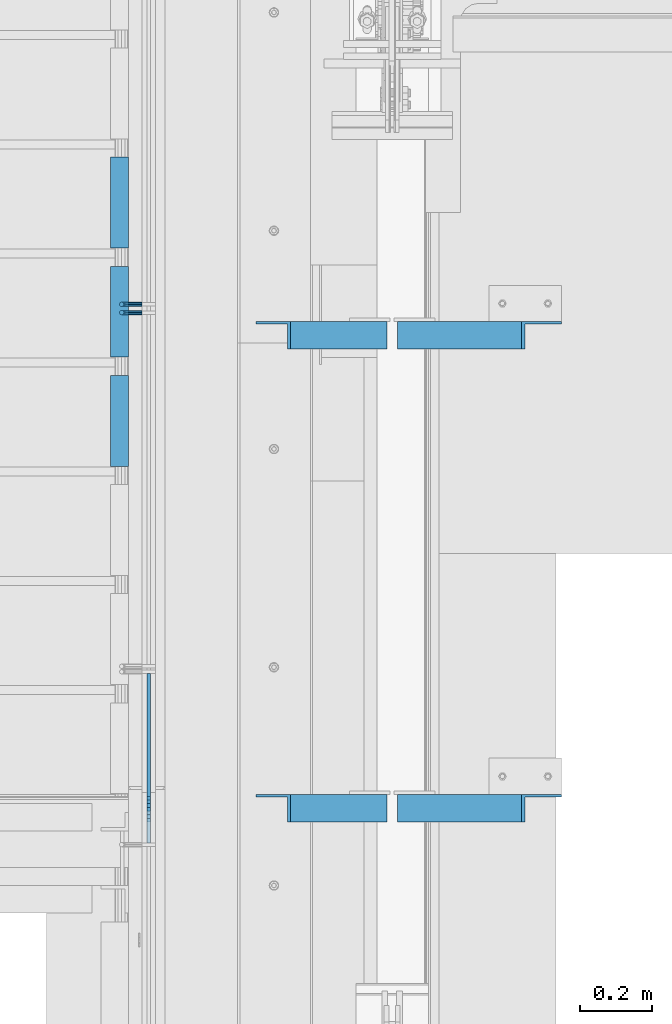
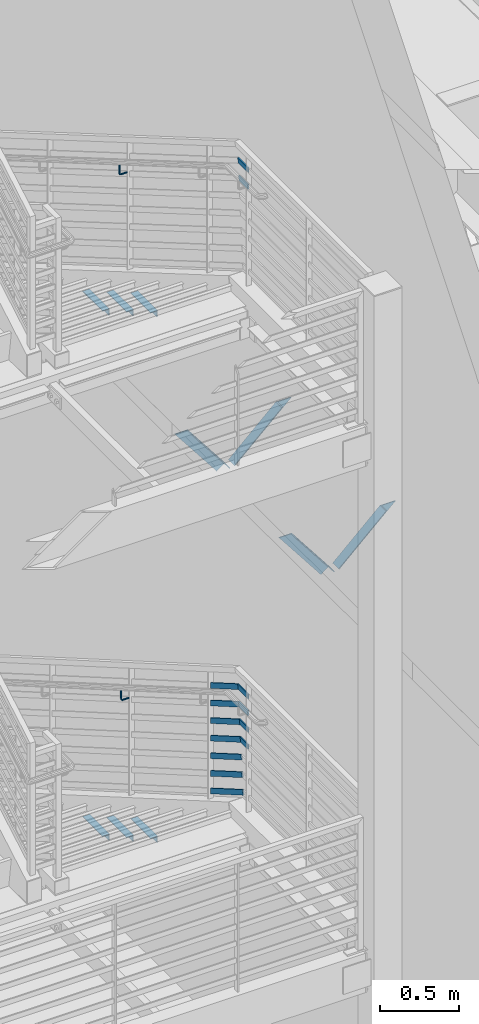
# One storey, part 868 of 1179: 14 beams, 11 members, 8 elements without a shape of their own.
"""IFC2X3 building model written with IfcOpenShell, lengths in millimetres."""

import ifcopenshell
import ifcopenshell.guid

model = None  # the IFC model being written
_history = None  # IfcOwnerHistory: only IFC2X3 demands one
_inside = {}  # id of a spatial element -> (the spatial element, [elements in it])
_under = {}  # id of a project, library or spatial element -> (it, [spatial elements below it])
_declared = {}  # id of a project -> (the project, [libraries it declares])
_typed = {}  # id of a type object -> (the type object, [elements of that type])
_made_of = {}  # id of a material, layer set ... -> (it, [elements and type objects made of it])


def new_model(schema):
    """Start an empty IFC model of exactly this schema.

    Asked for "IFC4X3", IfcOpenShell would pick the latest addendum, in which some entities
    have other attributes; the version numbers below select the first issue.
    IFC2X3 requires an IfcOwnerHistory on every rooted entity: one is made here for all.
    """
    global model, _history
    if schema == "IFC4X3":
        model = ifcopenshell.file(schema_version=(4, 3, 0, 0))
    else:
        model = ifcopenshell.file(schema=schema)
    _inside.clear()
    _under.clear()
    _declared.clear()
    _typed.clear()
    _made_of.clear()
    _history = None
    if model.schema == "IFC2X3":
        org = make("IfcOrganization", Name="unknown")
        user = make(
            "IfcPersonAndOrganization",
            ThePerson=make("IfcPerson", FamilyName="unknown"),
            TheOrganization=org,
        )
        app = make(
            "IfcApplication",
            ApplicationDeveloper=org,
            Version="unknown",
            ApplicationFullName="unknown",
            ApplicationIdentifier="unknown",
        )
        _history = make(
            "IfcOwnerHistory",
            OwningUser=user,
            OwningApplication=app,
            ChangeAction="ADDED",
            CreationDate=0,
        )
    return model


def make(cls, **values):
    """One entity of the class cls with the attributes given. An attribute that is None is left unset."""
    return model.create_entity(
        cls, **{name: value for name, value in values.items() if value is not None}
    )


def rooted(cls, **values):
    """An entity with a GlobalId (a new one), such as an element, a storey or a relation."""
    return make(cls, GlobalId=ifcopenshell.guid.new(), OwnerHistory=_history, **values)


def si_unit(unit_type, name, prefix=None):
    """IfcSIUnit, for example si_unit("LENGTHUNIT", "METRE", prefix="MILLI")."""
    return make("IfcSIUnit", UnitType=unit_type, Prefix=prefix, Name=name)


def assignment(units):
    """IfcUnitAssignment: the units of a project."""
    return None if units is None else make("IfcUnitAssignment", Units=units)


def point(xyz):
    """IfcCartesianPoint."""
    return None if xyz is None else make("IfcCartesianPoint", Coordinates=xyz)


def direction(xyz):
    """IfcDirection."""
    return None if xyz is None else make("IfcDirection", DirectionRatios=xyz)


def frame(location, z_axis=None, x_axis=None):
    """IfcAxis2Placement3D, a coordinate frame: its origin and axes. An axis left out is left unset."""
    return make(
        "IfcAxis2Placement3D",
        Location=point(location),
        Axis=direction(z_axis),
        RefDirection=direction(x_axis),
    )


def origin_with_axes():
    """The frame at (0, 0, 0) with the z axis (0, 0, 1) and the x axis (1, 0, 0) written out."""
    return frame((0.0, 0.0, 0.0), z_axis=(0.0, 0.0, 1.0), x_axis=(1.0, 0.0, 0.0))


def place(relative_to, where):
    """IfcLocalPlacement: puts the frame where relative to a parent placement (None: the world)."""
    return make(
        "IfcLocalPlacement", PlacementRelTo=relative_to, RelativePlacement=where
    )


def context(
    kind, dimensions, precision=None, world=None, true_north=None, identifier=None
):
    """IfcGeometricRepresentationContext, for example the 3D "Model" context."""
    return make(
        "IfcGeometricRepresentationContext",
        ContextIdentifier=identifier,
        ContextType=kind,
        CoordinateSpaceDimension=dimensions,
        Precision=precision,
        WorldCoordinateSystem=world,
        TrueNorth=true_north,
    )


def subcontext(parent, identifier, kind, view, scale=None):
    """IfcGeometricRepresentationSubContext, for example "Body" below "Model"."""
    return make(
        "IfcGeometricRepresentationSubContext",
        ContextIdentifier=identifier,
        ContextType=kind,
        ParentContext=parent,
        TargetScale=scale,
        TargetView=view,
    )


def project(units=None, contexts=None):
    """IfcProject with its units and contexts."""
    return rooted(
        "IfcProject",
        Name="project",
        RepresentationContexts=contexts,
        UnitsInContext=assignment(units),
    )


def spatial(cls, under=None, at=None, **own):
    """A site, building, storey or space (cls), placed at a placement, below another one or the project."""
    s = rooted(cls, ObjectPlacement=at, **own)
    if under is not None:
        _under.setdefault(under.id(), (under, []))[1].append(s)
    return s


def faces_of(points, faces, orient=None, outer=None):
    """IfcFace entities. A face is a list of loops; a loop is a list of indices into points, from 0.

    orient and outer hold one flag for each loop. By default every Orientation is true, the
    first loop of a face is its IfcFaceOuterBound and the others are IfcFaceBound.
    """
    made = []
    for i, loops in enumerate(faces):
        bounds = []
        for j, loop in enumerate(loops):
            is_outer = j == 0 if outer is None else outer[i][j]
            bounds.append(
                make(
                    "IfcFaceOuterBound" if is_outer else "IfcFaceBound",
                    Bound=make("IfcPolyLoop", Polygon=[points[k] for k in loop]),
                    Orientation=True if orient is None else orient[i][j],
                )
            )
        made.append(make("IfcFace", Bounds=bounds))
    return made


def faceted_brep(points, faces, orient=None, outer=None, voids=None):
    """IfcFacetedBrep: a solid bounded by flat faces; with voids (closed shells), ...WithVoids."""
    shared = [point(p) for p in points]
    hull = make("IfcClosedShell", CfsFaces=faces_of(shared, faces, orient, outer))
    if voids is None:
        return make("IfcFacetedBrep", Outer=hull)
    return make(
        "IfcFacetedBrepWithVoids",
        Outer=hull,
        Voids=[
            make(cls, CfsFaces=faces_of(shared, fs, o, b)) for cls, fs, o, b in voids
        ],
    )


def shape(context_of_items, identifier, shape_type, items):
    """IfcShapeRepresentation: the items that make up one representation, for example the "Body"."""
    return make(
        "IfcShapeRepresentation",
        ContextOfItems=context_of_items,
        RepresentationIdentifier=identifier,
        RepresentationType=shape_type,
        Items=items,
    )


def material(Name=None, Category=None):
    """IfcMaterial."""
    return make("IfcMaterial", Name=Name, Category=Category)


def made_of(thing, what):
    """Note that an element or type object is made of a material, layer set ...; save() writes the relation."""
    if what is not None:
        _made_of.setdefault(what.id(), (what, []))[1].append(thing)
    return thing


def type_object(cls, material=None, **own):
    """A type object (cls), such as IfcWallType, which elements share."""
    return made_of(rooted(cls, **own), material)


def element(
    cls,
    number,
    at=None,
    inside=None,
    cuts=None,
    type_object=None,
    material=None,
    context=None,
    identifier="Body",
    shape_type=None,
    held_by="IfcProductDefinitionShape",
    body=None,
    shapes=None,
    **own,
):
    """One element of the class cls, such as IfcWall. Its Tag is "e" and its number.

    at: its placement. inside: the storey or other place that contains it. cuts: it is an
    opening in that element (IfcRelVoidsElement). A single representation is given by context,
    identifier, shape_type and body (its items); several are given by shapes. held_by: the class
    of the entity that holds the representations. save() writes the other relations.
    """
    e = rooted(cls, Tag="e%d" % number, ObjectPlacement=at, **own)
    if body is not None:
        shapes = [shape(context, identifier, shape_type, body)]
    if shapes is not None:
        e.Representation = make(held_by, Representations=shapes)
    if inside is not None:
        _inside.setdefault(inside.id(), (inside, []))[1].append(e)
    if cuts is not None:
        rooted(
            "IfcRelVoidsElement", RelatingBuildingElement=cuts, RelatedOpeningElement=e
        )
    if type_object is not None:
        _typed.setdefault(type_object.id(), (type_object, []))[1].append(e)
    return made_of(e, material)


def aggregate(whole, parts):
    """IfcRelAggregates: a whole, such as a stair, and the parts it consists of."""
    return rooted("IfcRelAggregates", RelatingObject=whole, RelatedObjects=parts)


def save(model, path):
    """Write the relations noted so far, then the file.

    IfcRelAggregates (storeys below a building ...), IfcRelContainedInSpatialStructure (elements
    in a storey), IfcRelDefinesByType, IfcRelAssociatesMaterial and IfcRelDeclares: one each for
    every whole, place, type object, material and project.
    """
    for whole, parts in _under.values():
        aggregate(whole, parts)
    for where, things in _inside.values():
        rooted(
            "IfcRelContainedInSpatialStructure",
            RelatedElements=things,
            RelatingStructure=where,
        )
    for kind, things in _typed.values():
        rooted("IfcRelDefinesByType", RelatedObjects=things, RelatingType=kind)
    for what, things in _made_of.values():
        rooted("IfcRelAssociatesMaterial", RelatedObjects=things, RelatingMaterial=what)
    for by, libraries in _declared.values():
        rooted("IfcRelDeclares", RelatingContext=by, RelatedDefinitions=libraries)
    model.write(path)


model = new_model("IFC2X3")

# Units and contexts
model_context = context("Model", 3, precision=1e-05, world=origin_with_axes())
body_context = subcontext(model_context, "Body", "Model", "MODEL_VIEW")
ifc_project = project(units=[si_unit("LENGTHUNIT", "METRE", prefix="MILLI"), si_unit("AREAUNIT", "SQUARE_METRE"), si_unit("VOLUMEUNIT", "CUBIC_METRE"), si_unit("MASSUNIT", "GRAM", prefix="KILO"), si_unit("TIMEUNIT", "SECOND"), si_unit("PLANEANGLEUNIT", "RADIAN"), si_unit("SOLIDANGLEUNIT", "STERADIAN"), si_unit("THERMODYNAMICTEMPERATUREUNIT", "DEGREE_CELSIUS"), si_unit("LUMINOUSINTENSITYUNIT", "LUMEN")], contexts=[model_context])

# Site, building, storey
site_placement = place(None, origin_with_axes())
site = spatial("IfcSite", under=ifc_project, at=site_placement, CompositionType="ELEMENT")
building_placement = place(site_placement, origin_with_axes())
building = spatial("IfcBuilding", under=site, at=building_placement, Name="Undefined", CompositionType="ELEMENT")
storey_placement = place(building_placement, origin_with_axes())
storey = spatial("IfcBuildingStorey", under=building, at=storey_placement, Name="Undefined", CompositionType="ELEMENT", Elevation=0.0)

# Assembly, beams
assembly_1_placement = place(storey_placement, origin_with_axes())
assembly_1 = element("IfcElementAssembly", 1, at=assembly_1_placement, inside=storey, Name="STRINGER", AssemblyPlace="NOTDEFINED", PredefinedType="RIGID_FRAME")
ifc_material = material(Name="STEEL/A36")
beam_type_1 = type_object("IfcBeamType", Name="L2X2X3/16", PredefinedType="NOTDEFINED")
beam_1_placement = place(assembly_1_placement, frame((-330.199999984874, 33060.3356226176, 5400.67499956045), z_axis=(-1.0, 0.0, 0.0), x_axis=(0.0, -1.0, 0.0)))
beam_1 = element("IfcBeam", 2, at=beam_1_placement, type_object=beam_type_1, material=ifc_material, Name="ANGLE", ObjectType="L2X2X3/16", context=body_context, shape_type="Brep", body=[
    faceted_brep([(0.0, 25.3999999999996, -25.4000000000015), (0.0, 25.3999999999996, 25.4000000000015), (254.0, 25.3999999999996, 25.4000000000001), (254.0, 25.3999999999996, -25.4000000000001), (0.0, 20.6374999999998, 25.4000000000015), (254.0, 20.6374999999998, 25.4000000000001), (0.0, 20.6374999999998, -20.6374999999971), (254.0, 20.6374999999998, -20.6374999999998), (0.0, -25.3999999999996, -20.6374999999971), (254.0, -25.3999999999996, -20.6374999999998), (0.0, -25.3999999999996, -25.4000000000015), (254.0, -25.3999999999996, -25.4000000000001)], [[[0, 1, 2, 3]], [[1, 4, 5, 2]], [[4, 6, 7, 5]], [[6, 8, 9, 7]], [[8, 10, 11, 9]], [[10, 0, 3, 11]], [[5, 7, 9, 11, 3, 2]], [[10, 8, 6, 4, 1, 0]]]),
])
beam_2_placement = place(assembly_1_placement, frame((-330.19999998693, 33365.1356225536, 5222.87499945075), z_axis=(-1.0, 0.0, 0.0), x_axis=(0.0, -1.0, 0.0)))
beam_2 = element("IfcBeam", 3, at=beam_2_placement, type_object=beam_type_1, material=ifc_material, Name="ANGLE", ObjectType="L2X2X3/16", context=body_context, shape_type="Brep", body=[
    faceted_brep([(0.0, 25.3999999999996, -25.4000000000015), (0.0, 25.3999999999996, 25.4000000000015), (254.0, 25.3999999999996, 25.4000000000001), (254.0, 25.3999999999996, -25.4000000000001), (0.0, 20.6374999999998, 25.4000000000015), (254.0, 20.6374999999998, 25.4000000000001), (0.0, 20.6374999999998, -20.6374999999971), (254.0, 20.6374999999998, -20.6374999999998), (0.0, -25.3999999999996, -20.6374999999971), (254.0, -25.3999999999996, -20.6374999999998), (0.0, -25.3999999999996, -25.4000000000015), (254.0, -25.3999999999996, -25.4000000000001)], [[[0, 1, 2, 3]], [[1, 4, 5, 2]], [[4, 6, 7, 5]], [[6, 8, 9, 7]], [[8, 10, 11, 9]], [[10, 0, 3, 11]], [[5, 7, 9, 11, 3, 2]], [[10, 8, 6, 4, 1, 0]]]),
])
beam_3_placement = place(assembly_1_placement, frame((-330.199999988985, 33669.9356224896, 5045.07499934105), z_axis=(-1.0, 0.0, 0.0), x_axis=(0.0, -1.0, 0.0)))
beam_3 = element("IfcBeam", 4, at=beam_3_placement, type_object=beam_type_1, material=ifc_material, Name="ANGLE", ObjectType="L2X2X3/16", context=body_context, shape_type="Brep", body=[
    faceted_brep([(0.0, 25.3999999999996, -25.4000000000015), (0.0, 25.3999999999996, 25.4000000000015), (254.0, 25.3999999999996, 25.4000000000001), (254.0, 25.3999999999996, -25.4000000000001), (0.0, 20.6374999999998, 25.4000000000015), (254.0, 20.6374999999998, 25.4000000000001), (0.0, 20.6374999999998, -20.6374999999971), (254.0, 20.6374999999998, -20.6374999999998), (0.0, -25.3999999999996, -20.6374999999971), (254.0, -25.3999999999996, -20.6374999999998), (0.0, -25.3999999999996, -25.4000000000015), (254.0, -25.3999999999996, -25.4000000000001)], [[[0, 1, 2, 3]], [[1, 4, 5, 2]], [[4, 6, 7, 5]], [[6, 8, 9, 7]], [[8, 10, 11, 9]], [[10, 0, 3, 11]], [[5, 7, 9, 11, 3, 2]], [[10, 8, 6, 4, 1, 0]]]),
])
aggregate(assembly_1, [beam_1, beam_2, beam_3])

assembly_2_placement = place(storey_placement, origin_with_axes())
assembly_2 = element("IfcElementAssembly", 5, at=assembly_2_placement, inside=storey, Name="STRINGER", AssemblyPlace="NOTDEFINED", PredefinedType="RIGID_FRAME")
beam_4_placement = place(assembly_2_placement, frame((-330.200000005452, 33060.2814779887, 1332.47534229106), z_axis=(-1.0, 0.0, 0.0), x_axis=(0.0, -1.0, 0.0)))
beam_4 = element("IfcBeam", 6, at=beam_4_placement, type_object=beam_type_1, material=ifc_material, Name="ANGLE", ObjectType="L2X2X3/16", context=body_context, shape_type="Brep", body=[
    faceted_brep([(0.0, 25.3999999999996, -25.4000000000015), (0.0, 25.3999999999996, 25.4000000000015), (254.0, 25.3999999999996, 25.4000000000001), (254.0, 25.3999999999996, -25.4000000000001), (0.0, 20.6374999999998, 25.4000000000015), (254.0, 20.6374999999998, 25.4000000000001), (0.0, 20.6374999999998, -20.6374999999971), (254.0, 20.6374999999998, -20.6374999999998), (0.0, -25.3999999999996, -20.6374999999971), (254.0, -25.3999999999996, -20.6374999999998), (0.0, -25.3999999999996, -25.4000000000015), (254.0, -25.3999999999996, -25.4000000000001)], [[[0, 1, 2, 3]], [[1, 4, 5, 2]], [[4, 6, 7, 5]], [[6, 8, 9, 7]], [[8, 10, 11, 9]], [[10, 0, 3, 11]], [[5, 7, 9, 11, 3, 2]], [[10, 8, 6, 4, 1, 0]]]),
])
beam_5_placement = place(assembly_2_placement, frame((-330.200000005412, 33365.0816317228, 1155.99344815391), z_axis=(-1.0, 0.0, 0.0), x_axis=(0.0, -1.0, 0.0)))
beam_5 = element("IfcBeam", 7, at=beam_5_placement, type_object=beam_type_1, material=ifc_material, Name="ANGLE", ObjectType="L2X2X3/16", context=body_context, shape_type="Brep", body=[
    faceted_brep([(0.0, 25.3999999999996, -25.4000000000015), (0.0, 25.3999999999996, 25.4000000000015), (254.0, 25.3999999999996, 25.4000000000001), (254.0, 25.3999999999996, -25.4000000000001), (0.0, 20.6374999999998, 25.4000000000015), (254.0, 20.6374999999998, 25.4000000000001), (0.0, 20.6374999999998, -20.6374999999971), (254.0, 20.6374999999998, -20.6374999999998), (0.0, -25.3999999999996, -20.6374999999971), (254.0, -25.3999999999996, -20.6374999999998), (0.0, -25.3999999999996, -25.4000000000015), (254.0, -25.3999999999996, -25.4000000000001)], [[[0, 1, 2, 3]], [[1, 4, 5, 2]], [[4, 6, 7, 5]], [[6, 8, 9, 7]], [[8, 10, 11, 9]], [[10, 0, 3, 11]], [[5, 7, 9, 11, 3, 2]], [[10, 8, 6, 4, 1, 0]]]),
])
beam_6_placement = place(assembly_2_placement, frame((-330.200000005372, 33669.8817854569, 979.51155401677), z_axis=(-1.0, 0.0, 0.0), x_axis=(0.0, -1.0, 0.0)))
beam_6 = element("IfcBeam", 8, at=beam_6_placement, type_object=beam_type_1, material=ifc_material, Name="ANGLE", ObjectType="L2X2X3/16", context=body_context, shape_type="Brep", body=[
    faceted_brep([(0.0, 25.3999999999996, -25.4000000000015), (0.0, 25.3999999999996, 25.4000000000015), (254.0, 25.3999999999996, 25.4000000000001), (254.0, 25.3999999999996, -25.4000000000001), (0.0, 20.6374999999998, 25.4000000000015), (254.0, 20.6374999999998, 25.4000000000001), (0.0, 20.6374999999998, -20.6374999999971), (254.0, 20.6374999999998, -20.6374999999998), (0.0, -25.3999999999996, -20.6374999999971), (254.0, -25.3999999999996, -20.6374999999998), (0.0, -25.3999999999996, -25.4000000000015), (254.0, -25.3999999999996, -25.4000000000001)], [[[0, 1, 2, 3]], [[1, 4, 5, 2]], [[4, 6, 7, 5]], [[6, 8, 9, 7]], [[8, 10, 11, 9]], [[10, 0, 3, 11]], [[5, 7, 9, 11, 3, 2]], [[10, 8, 6, 4, 1, 0]]]),
])
aggregate(assembly_2, [beam_4, beam_5, beam_6])

# Assembly, beam
assembly_3_placement = place(storey_placement, origin_with_axes())
assembly_3 = element("IfcElementAssembly", 9, at=assembly_3_placement, inside=storey, Name="GUARDRAIL", AssemblyPlace="NOTDEFINED", PredefinedType="RIGID_FRAME")
beam_type_2 = type_object("IfcBeamType", PredefinedType="NOTDEFINED")
beam_7_placement = place(assembly_3_placement, frame((-266.699999255495, 33258.759324803, 6208.77780560445), z_axis=(0.0, 0.0, 1.0), x_axis=(-1.0, 0.0, 0.0)))
beam_7 = element("IfcBeam", 10, at=beam_7_placement, type_object=beam_type_2, material=ifc_material, Name="BRACKET", context=body_context, shape_type="Brep", body=[
    faceted_brep([(0.0, -4.49012806053361, 4.49012806053452), (0.0, 0.0, 6.34999999999991), (0.0, 4.49012806053361, 4.49012806053452), (0.0, 6.34999999999854, 0.0), (0.0, 4.49012806053361, -4.49012806053452), (0.0, 0.0, -6.34999999999991), (0.0, -4.49012806053361, -4.49012806053452), (0.0, -6.34999999999854, 0.0), (44.4500031699827, 0.0, -6.34999999999991), (44.4500031699827, -4.49012806053361, -4.49012806053452), (44.4500031699827, -6.34999999999854, 2.19733919948339e-09), (44.4500031699827, -4.49012806053361, 4.49012806053452), (44.4500031699827, 0.0, 6.34999999999991), (44.4500031699827, 4.49012806053361, 4.49012806053452), (44.4500031699827, 6.34999999999854, 0.0), (44.4500031699827, 4.49012806053361, -4.49012806053452), (53.0450671075391, 4.4901280570557, -2.18708762112465), (53.97500307462, -4.32919478043914e-09, -3.79778396764459), (53.0450671022344, -4.49012806401151, -2.1870876194389), (50.8000030708674, -6.35000000142099, 1.70147734757802), (48.5549390416977, -4.4901280599006, 5.59004231389645), (47.6250030746168, 1.48793333210051e-09, 7.20073866041594), (48.5549390470023, 4.49012806117025, 5.5900423122107), (50.8000030783693, 6.34999999857973, 1.70147734519378), (55.4485256393576, 6.34999999469437, 6.34999990618098), (59.337090604122, 4.49012805180246, 4.10493587545716), (51.5599606707875, 4.49012805866005, 8.59506393599531), (49.9492643188311, -4.54747350886464e-10, 9.52499990463002), (51.5599606615996, -4.4901280624108, 8.59506393379797), (55.4485256263639, -6.35000000530636, 6.34999990307369), (59.337090594938, -4.49012806926839, 4.10493587326664), (60.9477869468905, -1.0153598850593e-08, 3.17499990462466), (61.6401310450869, 4.49012804462109, 12.6999998130159), (63.5000029792477, -1.81098585017025e-08, 12.6999998092651), (57.1500029867496, 6.3499999893902, 12.6999998145698), (52.6598749240178, 4.49012805522943, 12.6999998130159), (50.8000029792477, -3.10683390125632e-09, 12.6999998092651), (52.6598749134085, -4.49012806583778, 12.6999998055144), (57.1500029739432, -6.35000001061053, 12.6999998039605), (61.6401310344776, -4.49012807644976, 12.6999998055144), (63.5000029792478, -6.94672053214163e-08, 76.1999999999989), (61.6401294880352, -4.49012904147821, 73.5807586715764), (57.1500014109847, -6.35000090467656, 72.4958334126568), (52.6598733669657, -4.49012891602615, 73.5807587357776), (50.8000029792478, -5.78438630327582e-08, 76.1999999999989), (52.6598734909962, 4.49012713825505, 78.8192414384375), (57.1500015765077, 6.34999900287221, 79.9041666981866), (61.6401296120657, 4.49012701564061, 78.8192413758952)], [[[0, 1, 2, 3, 4, 5, 6, 7]], [[6, 5, 8, 9]], [[7, 6, 9, 10]], [[0, 7, 10, 11]], [[1, 0, 11, 12]], [[2, 1, 12, 13]], [[3, 2, 13, 14]], [[4, 3, 14, 15]], [[5, 4, 15, 8]], [[8, 15, 16, 17]], [[9, 8, 17, 18]], [[10, 9, 18, 19]], [[11, 10, 19, 20]], [[12, 11, 20, 21]], [[13, 12, 21, 22]], [[14, 13, 22, 23]], [[15, 14, 23, 16]], [[23, 24, 25, 16]], [[22, 26, 24, 23]], [[21, 27, 26, 22]], [[20, 28, 27, 21]], [[19, 29, 28, 20]], [[18, 30, 29, 19]], [[17, 31, 30, 18]], [[16, 25, 31, 17]], [[25, 32, 33, 31]], [[24, 34, 32, 25]], [[26, 35, 34, 24]], [[27, 36, 35, 26]], [[28, 37, 36, 27]], [[29, 38, 37, 28]], [[30, 39, 38, 29]], [[31, 33, 39, 30]], [[39, 33, 40, 41]], [[38, 39, 41, 42]], [[37, 38, 42, 43]], [[36, 37, 43, 44]], [[35, 36, 44, 45]], [[34, 35, 45, 46]], [[32, 34, 46, 47]], [[33, 32, 47, 40]], [[46, 45, 44, 43, 42, 41, 40, 47]]]),
])

assembly_4_placement = place(storey_placement, origin_with_axes())
assembly_4 = element("IfcElementAssembly", 11, at=assembly_4_placement, inside=storey, Name="GUARDRAIL", AssemblyPlace="NOTDEFINED", PredefinedType="RIGID_FRAME")
beam_8_placement = place(assembly_4_placement, frame((-266.699999255495, 33235.9000011132, 2154.50375560792), z_axis=(0.0, 0.0, 1.0), x_axis=(-1.0, 0.0, 0.0)))
beam_8 = element("IfcBeam", 12, at=beam_8_placement, type_object=beam_type_2, material=ifc_material, Name="BRACKET", context=body_context, shape_type="Brep", body=[
    faceted_brep([(0.0, -4.49012806053361, 4.49012806053452), (0.0, 0.0, 6.34999999999991), (0.0, 4.49012806053361, 4.49012806053452), (0.0, 6.34999999999854, 0.0), (0.0, 4.49012806053361, -4.49012806053452), (0.0, 0.0, -6.34999999999991), (0.0, -4.49012806053361, -4.49012806053452), (0.0, -6.34999999999854, 0.0), (44.4500031699827, 0.0, -6.34999999999991), (44.4500031699827, -4.49012806053361, -4.49012806053452), (44.4500031699827, -6.34999999999854, 2.19733919948339e-09), (44.4500031699827, -4.49012806053361, 4.49012806053452), (44.4500031699827, 0.0, 6.34999999999991), (44.4500031699827, 4.49012806053361, 4.49012806053452), (44.4500031699827, 6.34999999999854, 0.0), (44.4500031699827, 4.49012806053361, -4.49012806053452), (53.0450671075391, 4.4901280570557, -2.18708762112465), (53.97500307462, -4.32919478043914e-09, -3.79778396764459), (53.0450671022344, -4.49012806401151, -2.1870876194389), (50.8000030708674, -6.35000000142099, 1.70147734757802), (48.5549390416977, -4.4901280599006, 5.59004231389645), (47.6250030746168, 1.48793333210051e-09, 7.20073866041594), (48.5549390470023, 4.49012806117025, 5.5900423122107), (50.8000030783693, 6.34999999857973, 1.70147734519378), (55.4485256393576, 6.34999999469437, 6.34999990618098), (59.337090604122, 4.49012805180246, 4.10493587545716), (51.5599606707875, 4.49012805866005, 8.59506393599531), (49.9492643188311, -4.54747350886464e-10, 9.52499990463002), (51.5599606615996, -4.4901280624108, 8.59506393379797), (55.4485256263639, -6.35000000530636, 6.34999990307369), (59.337090594938, -4.49012806926839, 4.10493587326664), (60.9477869468905, -1.0153598850593e-08, 3.17499990462466), (61.6401310450869, 4.49012804462109, 12.6999998130159), (63.5000029792477, -1.81098585017025e-08, 12.6999998092651), (57.1500029867496, 6.3499999893902, 12.6999998145698), (52.6598749240178, 4.49012805522943, 12.6999998130159), (50.8000029792477, -3.10683390125632e-09, 12.6999998092651), (52.6598749134085, -4.49012806583778, 12.6999998055144), (57.1500029739432, -6.35000001061053, 12.6999998039605), (61.6401310344776, -4.49012807644976, 12.6999998055144), (63.5000029792478, -6.94672053214163e-08, 76.1999999999989), (61.6401296086745, -4.49012715444769, 73.6001774342253), (57.1500015634042, -6.3499991642384, 72.5232956440923), (52.6598734876054, -4.49012727027366, 73.6001773671605), (50.8000029792478, -5.78438630327582e-08, 76.1999999999989), (52.6598733730815, 4.4901289120171, 78.79982245163), (57.150001410549, 6.35000092050541, 79.8767042410086), (61.6401294941506, 4.49012902523828, 78.7998225171859)], [[[0, 1, 2, 3, 4, 5, 6, 7]], [[6, 5, 8, 9]], [[7, 6, 9, 10]], [[0, 7, 10, 11]], [[1, 0, 11, 12]], [[2, 1, 12, 13]], [[3, 2, 13, 14]], [[4, 3, 14, 15]], [[5, 4, 15, 8]], [[8, 15, 16, 17]], [[9, 8, 17, 18]], [[10, 9, 18, 19]], [[11, 10, 19, 20]], [[12, 11, 20, 21]], [[13, 12, 21, 22]], [[14, 13, 22, 23]], [[15, 14, 23, 16]], [[23, 24, 25, 16]], [[22, 26, 24, 23]], [[21, 27, 26, 22]], [[20, 28, 27, 21]], [[19, 29, 28, 20]], [[18, 30, 29, 19]], [[17, 31, 30, 18]], [[16, 25, 31, 17]], [[25, 32, 33, 31]], [[24, 34, 32, 25]], [[26, 35, 34, 24]], [[27, 36, 35, 26]], [[28, 37, 36, 27]], [[29, 38, 37, 28]], [[30, 39, 38, 29]], [[31, 33, 39, 30]], [[39, 33, 40, 41]], [[38, 39, 41, 42]], [[37, 38, 42, 43]], [[36, 37, 43, 44]], [[35, 36, 44, 45]], [[34, 35, 45, 46]], [[32, 34, 46, 47]], [[33, 32, 47, 40]], [[46, 45, 44, 43, 42, 41, 40, 47]]]),
])

# Beam
beam_type_3 = type_object("IfcBeamType", PredefinedType="NOTDEFINED")
beam_9_placement = place(assembly_3_placement, frame((-247.650000711891, 31841.0069917113, 7000.87500003556), z_axis=(0.0, 0.0, 1.0), x_axis=(0.0, -1.0, 0.0)))
beam_9 = element("IfcBeam", 13, at=beam_9_placement, type_object=beam_type_3, material=ifc_material, Name="PLATE", context=body_context, shape_type="Brep", body=[
    faceted_brep([(-22.9619603103856, 4.76249999999999, -19.0500000000002), (-33.2622625921977, 4.76249999999999, 19.0500000000002), (86.2461825391219, 4.76249999999999, 19.0500000000002), (86.2461825391219, 4.76249999999999, -19.0500000000002), (-33.2622625921977, -4.76249999999999, 19.0500000000002), (86.2461825391219, -4.76249999999999, 19.0500000000002), (-22.9619603103856, -4.76249999999999, -19.0500000000002), (86.2461825391219, -4.76249999999999, -19.0500000000002)], [[[0, 1, 2, 3]], [[1, 4, 5, 2]], [[4, 6, 7, 5]], [[6, 0, 3, 7]], [[5, 7, 3, 2]], [[6, 4, 1, 0]]]),
])

beam_10_placement = place(assembly_3_placement, frame((-247.650000724804, 31851.8927060719, 7131.04999999123), z_axis=(0.0, 0.0, 1.0), x_axis=(0.0, -1.0, 0.0)))
beam_10 = element("IfcBeam", 14, at=beam_10_placement, type_object=beam_type_3, material=ifc_material, Name="PLATE", context=body_context, shape_type="Brep", body=[
    faceted_brep([(-22.3765490774094, 4.76249999999999, -19.0500000000002), (-32.6768513592251, 4.76249999999999, 19.0500000000002), (97.1318968997475, 4.76249999999999, 19.0500000000002), (97.1318968997475, 4.76249999999999, -19.0500000000002), (-32.6768513592251, -4.76249999999999, 19.0500000000002), (97.1318968997475, -4.76249999999999, 19.0500000000002), (-22.3765490774094, -4.76249999999999, -19.0500000000002), (97.1318968997475, -4.76249999999999, -19.0500000000002)], [[[0, 1, 2, 3]], [[1, 4, 5, 2]], [[4, 6, 7, 5]], [[6, 0, 3, 7]], [[5, 7, 3, 2]], [[6, 4, 1, 0]]]),
])

aggregate(assembly_3, [beam_7, beam_9, beam_10])

beam_11_placement = place(assembly_4_placement, frame((-247.650000724804, 31848.7630235135, 2667.05291886964), z_axis=(0.0, 0.0, 1.0), x_axis=(0.0, -1.0, 0.0)))
beam_11 = element("IfcBeam", 15, at=beam_11_placement, type_object=beam_type_3, material=ifc_material, Name="PLATE", context=body_context, shape_type="Brep", body=[
    faceted_brep([(5.11704109249331, 4.76249999999999, -19.0500000000002), (-5.1172028383553, 4.76249999999999, 19.0500000000002), (94.0022143409733, 4.76249999999999, 19.0500000000002), (94.0022143409733, 4.76249999999999, -19.0500000000002), (-5.1172028383553, -4.76249999999999, 19.0500000000002), (94.0022143409733, -4.76249999999999, 19.0500000000002), (5.11704109249331, -4.76249999999999, -19.0500000000002), (94.0022143409733, -4.76249999999999, -19.0500000000002)], [[[0, 1, 2, 3]], [[1, 4, 5, 2]], [[4, 6, 7, 5]], [[6, 0, 3, 7]], [[5, 7, 3, 2]], [[6, 4, 1, 0]]]),
])

beam_12_placement = place(assembly_4_placement, frame((-247.650000724804, 31858.9972675265, 2797.22791886683), z_axis=(0.0, 0.0, 1.0), x_axis=(0.0, -1.0, 0.0)))
beam_12 = element("IfcBeam", 16, at=beam_12_placement, type_object=beam_type_3, material=ifc_material, Name="PLATE", context=body_context, shape_type="Brep", body=[
    faceted_brep([(5.11710635485724, 4.76249999999999, -19.0500000000002), (-5.11713757599136, 4.76249999999999, 19.0500000000002), (104.236458353978, 4.76249999999999, 19.0500000000002), (104.236458353978, 4.76249999999999, -19.0500000000002), (-5.11713757599136, -4.76249999999999, 19.0500000000002), (104.236458353978, -4.76249999999999, 19.0500000000002), (5.11710635485724, -4.76249999999999, -19.0500000000002), (104.236458353978, -4.76249999999999, -19.0500000000002)], [[[0, 1, 2, 3]], [[1, 4, 5, 2]], [[4, 6, 7, 5]], [[6, 0, 3, 7]], [[5, 7, 3, 2]], [[6, 4, 1, 0]]]),
])

beam_13_placement = place(assembly_4_placement, frame((-247.650000724804, 31869.2315115286, 2927.40291887029), z_axis=(0.0, 0.0, 1.0), x_axis=(0.0, -1.0, 0.0)))
beam_13 = element("IfcBeam", 17, at=beam_13_placement, type_object=beam_type_3, material=ifc_material, Name="PLATE", context=body_context, shape_type="Brep", body=[
    faceted_brep([(5.11710635485724, 4.76249999999999, -19.0500000000002), (-5.11713757599136, 4.76249999999999, 19.0500000000002), (114.470702356146, 4.76249999999999, 19.0500000000002), (114.470702356146, 4.76249999999999, -19.0500000000002), (-5.11713757599136, -4.76249999999999, 19.0500000000002), (114.470702356146, -4.76249999999999, 19.0500000000002), (5.11710635485724, -4.76249999999999, -19.0500000000002), (114.470702356146, -4.76249999999999, -19.0500000000002)], [[[0, 1, 2, 3]], [[1, 4, 5, 2]], [[4, 6, 7, 5]], [[6, 0, 3, 7]], [[5, 7, 3, 2]], [[6, 4, 1, 0]]]),
])

beam_14_placement = place(assembly_4_placement, frame((-247.650000724804, 31879.4657555262, 3057.57791887665), z_axis=(0.0, 0.0, 1.0), x_axis=(0.0, -1.0, 0.0)))
beam_14 = element("IfcBeam", 18, at=beam_14_placement, type_object=beam_type_3, material=ifc_material, Name="PLATE", context=body_context, shape_type="Brep", body=[
    faceted_brep([(5.11710635485724, 4.76249999999999, -19.0500000000002), (-5.11713757599136, 4.76249999999999, 19.0500000000002), (124.704946353722, 4.76249999999999, 19.0500000000002), (124.704946353722, 4.76249999999999, -19.0500000000002), (-5.11713757599136, -4.76249999999999, 19.0500000000002), (124.704946353722, -4.76249999999999, 19.0500000000002), (5.11710635485724, -4.76249999999999, -19.0500000000002), (124.704946353722, -4.76249999999999, -19.0500000000002)], [[[0, 1, 2, 3]], [[1, 4, 5, 2]], [[4, 6, 7, 5]], [[6, 0, 3, 7]], [[5, 7, 3, 2]], [[6, 4, 1, 0]]]),
])

# Member
member_type_1 = type_object("IfcMemberType", PredefinedType="NOTDEFINED")
member_1_placement = place(assembly_4_placement, frame((-247.650000724804, 32223.0545867798, 2042.03280730917), z_axis=(0.0, 0.501075923252298, 0.865403327435744), x_axis=(0.0, -0.865403327435743, 0.501075923252299)))
member_1 = element("IfcMember", 19, at=member_1_placement, type_object=member_type_1, material=ifc_material, Name="PLATE", context=body_context, shape_type="Brep", body=[
    faceted_brep([(-16.5570104603576, 4.76250000000005, -19.0500000000102), (5.50317738577724, 4.76250000000005, 19.0499999999902), (473.10031504479, 4.76249999999999, 19.0499999999374), (462.866071120934, 4.76249999999999, -19.0500000000902), (5.50317738577724, -4.76250000000005, 19.0499999999902), (473.10031504479, -4.76249999999999, 19.0499999999374), (-16.5570104603576, -4.76250000000005, -19.0500000000102), (462.866071120934, -4.76249999999999, -19.0500000000902)], [[[0, 1, 2, 3]], [[1, 4, 5, 2]], [[4, 6, 7, 5]], [[6, 0, 3, 7]], [[5, 7, 3, 2]], [[6, 4, 1, 0]]]),
])

member_2_placement = place(assembly_4_placement, frame((-247.650000724804, 32223.0545713435, 2178.13352201121), z_axis=(0.0, 0.501075923252298, 0.865403327435744), x_axis=(0.0, -0.865403327435743, 0.501075923252299)))
member_2 = element("IfcMember", 20, at=member_2_placement, type_object=member_type_1, material=ifc_material, Name="PLATE", context=body_context, shape_type="Brep", body=[
    faceted_brep([(-16.5570104603576, 4.76250000000005, -19.0500000000102), (5.50317738577724, 4.76250000000005, 19.0499999999902), (461.274333335146, 4.76249999999999, 19.0499999999374), (451.040089411297, 4.76249999999999, -19.0500000000829), (5.50317738577724, -4.76250000000005, 19.0499999999902), (461.274333335146, -4.76249999999999, 19.0499999999374), (-16.5570104603576, -4.76250000000005, -19.0500000000102), (451.040089411297, -4.76249999999999, -19.0500000000829)], [[[0, 1, 2, 3]], [[1, 4, 5, 2]], [[4, 6, 7, 5]], [[6, 0, 3, 7]], [[5, 7, 3, 2]], [[6, 4, 1, 0]]]),
])

member_3_placement = place(assembly_4_placement, frame((-247.650000724804, 32223.0545553346, 2314.23423669977), z_axis=(0.0, 0.501075923252298, 0.865403327435744), x_axis=(0.0, -0.865403327435743, 0.501075923252299)))
member_3 = element("IfcMember", 21, at=member_3_placement, type_object=member_type_1, material=ifc_material, Name="PLATE", context=body_context, shape_type="Brep", body=[
    faceted_brep([(-16.5570104603576, 4.76250000000005, -19.0500000000102), (5.50317738577724, 4.76250000000005, 19.0499999999902), (449.448351672854, 4.76249999999999, 19.0499999999374), (439.214107748998, 4.76249999999999, -19.0500000000829), (5.50317738577724, -4.76250000000005, 19.0499999999902), (449.448351672854, -4.76249999999999, 19.0499999999374), (-16.5570104603576, -4.76250000000005, -19.0500000000102), (439.214107748998, -4.76249999999999, -19.0500000000829)], [[[0, 1, 2, 3]], [[1, 4, 5, 2]], [[4, 6, 7, 5]], [[6, 0, 3, 7]], [[5, 7, 3, 2]], [[6, 4, 1, 0]]]),
])

member_4_placement = place(assembly_4_placement, frame((-247.650000724804, 32223.0545387319, 2450.33495146761), z_axis=(0.0, 0.501075923252298, 0.865403327435744), x_axis=(0.0, -0.865403327435743, 0.501075923252299)))
member_4 = element("IfcMember", 22, at=member_4_placement, type_object=member_type_1, material=ifc_material, Name="PLATE", context=body_context, shape_type="Brep", body=[
    faceted_brep([(-16.5570104603576, 4.76250000000005, -19.0500000000102), (5.50317738577724, 4.76250000000005, 19.0499999999902), (437.622371856796, 4.76249999999999, 19.0499999999374), (427.388127932947, 4.76249999999999, -19.0500000000829), (5.50317738577724, -4.76250000000005, 19.0499999999902), (437.622371856796, -4.76249999999999, 19.0499999999374), (-16.5570104603576, -4.76250000000005, -19.0500000000102), (427.388127932947, -4.76249999999999, -19.0500000000829)], [[[0, 1, 2, 3]], [[1, 4, 5, 2]], [[4, 6, 7, 5]], [[6, 0, 3, 7]], [[5, 7, 3, 2]], [[6, 4, 1, 0]]]),
])

member_5_placement = place(assembly_4_placement, frame((-247.650000724804, 32223.0545215161, 2586.43566622128), z_axis=(0.0, 0.501075923252298, 0.865403327435744), x_axis=(0.0, -0.865403327435743, 0.501075923252299)))
member_5 = element("IfcMember", 23, at=member_5_placement, type_object=member_type_1, material=ifc_material, Name="PLATE", context=body_context, shape_type="Brep", body=[
    faceted_brep([(-16.5570104603576, 4.76250000000005, -19.0500000000102), (5.50317738577724, 4.76250000000005, 19.0499999999902), (425.796390041502, 4.76249999999999, 19.0499999999447), (415.562146117652, 4.76249999999999, -19.0500000000757), (5.50317738577724, -4.76250000000005, 19.0499999999902), (425.796390041502, -4.76249999999999, 19.0499999999447), (-16.5570104603576, -4.76250000000005, -19.0500000000102), (415.562146117652, -4.76249999999999, -19.0500000000757)], [[[0, 1, 2, 3]], [[1, 4, 5, 2]], [[4, 6, 7, 5]], [[6, 0, 3, 7]], [[5, 7, 3, 2]], [[6, 4, 1, 0]]]),
])

member_6_placement = place(assembly_4_placement, frame((-247.650000724804, 32223.054503666, 2722.53638097478), z_axis=(0.0, 0.501075923252298, 0.865403327435744), x_axis=(0.0, -0.865403327435743, 0.501075923252299)))
member_6 = element("IfcMember", 24, at=member_6_placement, type_object=member_type_1, material=ifc_material, Name="PLATE", context=body_context, shape_type="Brep", body=[
    faceted_brep([(-16.5570104603576, 4.76250000000005, -19.0500000000102), (5.50317738577724, 4.76250000000005, 19.0499999999902), (413.970408239045, 4.76249999999999, 19.0499999999411), (403.736164315196, 4.76249999999999, -19.0500000000793), (5.50317738577724, -4.76250000000005, 19.0499999999902), (413.970408239045, -4.76249999999999, 19.0499999999411), (-16.5570104603576, -4.76250000000005, -19.0500000000102), (403.736164315196, -4.76249999999999, -19.0500000000793)], [[[0, 1, 2, 3]], [[1, 4, 5, 2]], [[4, 6, 7, 5]], [[6, 0, 3, 7]], [[5, 7, 3, 2]], [[6, 4, 1, 0]]]),
])

member_7_placement = place(assembly_4_placement, frame((-247.650000724804, 32223.0545036902, 2858.63709566962), z_axis=(0.0, 0.501075923252298, 0.865403327435744), x_axis=(0.0, -0.865403327435743, 0.501075923252299)))
member_7 = element("IfcMember", 25, at=member_7_placement, type_object=member_type_1, material=ifc_material, Name="PLATE", context=body_context, shape_type="Brep", body=[
    faceted_brep([(-16.5570104603576, 4.76250000000005, -19.0500000000102), (5.50317738577724, 4.76250000000005, 19.0499999999902), (402.144426559415, 4.76249999999999, 19.0499999999483), (391.910182635565, 4.76249999999999, -19.050000000072), (5.50317738577724, -4.76250000000005, 19.0499999999902), (402.144426559415, -4.76249999999999, 19.0499999999483), (-16.5570104603576, -4.76250000000005, -19.0500000000102), (391.910182635565, -4.76249999999999, -19.050000000072)], [[[0, 1, 2, 3]], [[1, 4, 5, 2]], [[4, 6, 7, 5]], [[6, 0, 3, 7]], [[5, 7, 3, 2]], [[6, 4, 1, 0]]]),
])

aggregate(assembly_4, [beam_8, member_1, member_2, member_3, member_4, member_5, member_6, member_7, beam_11, beam_12, beam_13, beam_14])

# Assembly, member
assembly_5_placement = place(storey_placement, origin_with_axes())
assembly_5 = element("IfcElementAssembly", 26, at=assembly_5_placement, inside=storey, Name="ANGLE", AssemblyPlace="NOTDEFINED", PredefinedType="RIGID_FRAME")
member_type_2 = type_object("IfcMemberType", Name="L3X3X1/4", PredefinedType="NOTDEFINED")
member_8_placement = place(assembly_5_placement, frame((472.414639168566, 33172.4, 3736.19330123132), z_axis=(0.0, -1.0, 0.0), x_axis=(0.729484494811633, 0.0, 0.683997347823379)))
member_8 = element("IfcMember", 27, at=member_8_placement, type_object=member_type_2, material=ifc_material, Name="ANGLE", ObjectType="L3X3X1/4", context=body_context, shape_type="Brep", body=[
    faceted_brep([(0.0, 38.0999999999985, -38.0999999999999), (0.0, 38.0999999999985, 38.0999999999999), (475.752341075195, 38.0999999999181, 38.1000000000004), (475.752341075195, 38.0999999999181, -38.1000000000004), (0.0, 31.75, 38.1000000000004), (482.524628360803, 31.7499999999177, 38.1000000000004), (0.0, 31.75, -31.75), (482.524628360803, 31.7499999999177, -31.75), (0.0, -38.0999999999985, -31.75), (557.019788502486, -38.1000000000854, -31.75), (0.0, -38.0999999999985, -38.0999999999999), (557.019788502486, -38.1000000000854, -38.1000000000004)], [[[0, 1, 2, 3]], [[1, 4, 5, 2]], [[4, 6, 7, 5]], [[6, 8, 9, 7]], [[8, 10, 11, 9]], [[10, 0, 3, 11]], [[5, 7, 9, 11, 3, 2]], [[10, 8, 6, 4, 1, 0]]]),
])
aggregate(assembly_5, [member_8])

assembly_6_placement = place(storey_placement, origin_with_axes())
assembly_6 = element("IfcElementAssembly", 28, at=assembly_6_placement, inside=storey, Name="ANGLE", AssemblyPlace="NOTDEFINED", PredefinedType="RIGID_FRAME")
member_9_placement = place(assembly_6_placement, frame((80.8196258456501, 33172.4, 4125.56128839178), z_axis=(0.0, -1.0, 0.0), x_axis=(0.614083067285056, 0.0, -0.789241399366364)))
member_9 = element("IfcMember", 29, at=member_9_placement, type_object=member_type_2, material=ifc_material, Name="ANGLE", ObjectType="L3X3X1/4", context=body_context, shape_type="Brep", body=[
    faceted_brep([(59.3707492954454, 38.0999999999781, -38.1000000000004), (59.3707492954454, 38.0999999999781, 38.1000000000004), (499.083854779058, 38.0999999998585, 38.1000000000004), (499.083854779058, 38.0999999998585, -38.1000000000004), (54.4300207928691, 31.7499999999804, 38.1000000000004), (499.083854779056, 31.7499999998595, 38.1000000000004), (54.4300207928691, 31.7499999999804, -31.75), (499.083854779056, 31.7499999998595, -31.75), (0.0820072645328764, -38.0999999999945, -31.75), (499.083854779043, -38.10000000013, -31.75), (0.0820072645328764, -38.0999999999945, -38.1000000000004), (499.083854779043, -38.10000000013, -38.1000000000004)], [[[0, 1, 2, 3]], [[1, 4, 5, 2]], [[4, 6, 7, 5]], [[6, 8, 9, 7]], [[8, 10, 11, 9]], [[10, 0, 3, 11]], [[5, 7, 9, 11, 3, 2]], [[10, 8, 6, 4, 1, 0]]]),
])
aggregate(assembly_6, [member_9])

assembly_7_placement = place(storey_placement, origin_with_axes())
assembly_7 = element("IfcElementAssembly", 30, at=assembly_7_placement, inside=storey, Name="ANGLE", AssemblyPlace="NOTDEFINED", PredefinedType="RIGID_FRAME")
member_10_placement = place(assembly_7_placement, frame((472.414639168566, 31851.6, 3736.19330123132), z_axis=(0.0, -1.0, 0.0), x_axis=(0.729484494811633, 0.0, 0.683997347823379)))
member_10 = element("IfcMember", 31, at=member_10_placement, type_object=member_type_2, material=ifc_material, Name="ANGLE", ObjectType="L3X3X1/4", context=body_context, shape_type="Brep", body=[
    faceted_brep([(0.0, 38.0999999999985, -38.0999999999999), (0.0, 38.0999999999985, 38.0999999999999), (475.752341075195, 38.0999999999181, 38.1000000000004), (475.752341075195, 38.0999999999181, -38.1000000000004), (0.0, 31.75, 38.1000000000004), (482.524628360803, 31.7499999999177, 38.1000000000004), (0.0, 31.75, -31.75), (482.524628360803, 31.7499999999177, -31.75), (0.0, -38.0999999999985, -31.75), (557.019788502486, -38.1000000000854, -31.75), (0.0, -38.0999999999985, -38.0999999999999), (557.019788502486, -38.1000000000854, -38.1000000000004)], [[[0, 1, 2, 3]], [[1, 4, 5, 2]], [[4, 6, 7, 5]], [[6, 8, 9, 7]], [[8, 10, 11, 9]], [[10, 0, 3, 11]], [[5, 7, 9, 11, 3, 2]], [[10, 8, 6, 4, 1, 0]]]),
])
aggregate(assembly_7, [member_10])

assembly_8_placement = place(storey_placement, origin_with_axes())
assembly_8 = element("IfcElementAssembly", 32, at=assembly_8_placement, inside=storey, Name="ANGLE", AssemblyPlace="NOTDEFINED", PredefinedType="RIGID_FRAME")
member_11_placement = place(assembly_8_placement, frame((80.8196258456501, 31851.6, 4125.56128839178), z_axis=(0.0, -1.0, 0.0), x_axis=(0.614083067285056, 0.0, -0.789241399366364)))
member_11 = element("IfcMember", 33, at=member_11_placement, type_object=member_type_2, material=ifc_material, Name="ANGLE", ObjectType="L3X3X1/4", context=body_context, shape_type="Brep", body=[
    faceted_brep([(59.3707492954454, 38.0999999999781, -38.1000000000004), (59.3707492954454, 38.0999999999781, 38.1000000000004), (499.083854779058, 38.0999999998585, 38.1000000000004), (499.083854779058, 38.0999999998585, -38.1000000000004), (54.4300207928691, 31.7499999999804, 38.1000000000004), (499.083854779056, 31.7499999998595, 38.1000000000004), (54.4300207928691, 31.7499999999804, -31.75), (499.083854779056, 31.7499999998595, -31.75), (0.0820072645328764, -38.0999999999945, -31.75), (499.083854779043, -38.10000000013, -31.75), (0.0820072645328764, -38.0999999999945, -38.1000000000004), (499.083854779043, -38.10000000013, -38.1000000000004)], [[[0, 1, 2, 3]], [[1, 4, 5, 2]], [[4, 6, 7, 5]], [[6, 8, 9, 7]], [[8, 10, 11, 9]], [[10, 0, 3, 11]], [[5, 7, 9, 11, 3, 2]], [[10, 8, 6, 4, 1, 0]]]),
])
aggregate(assembly_8, [member_11])

save(model, "model.ifc")
